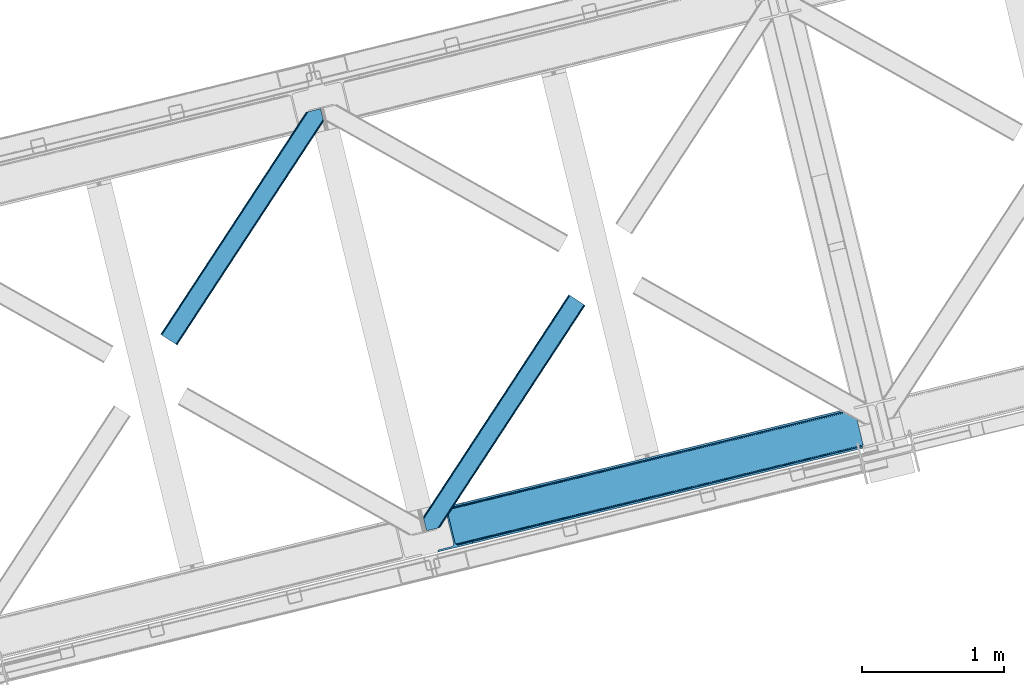
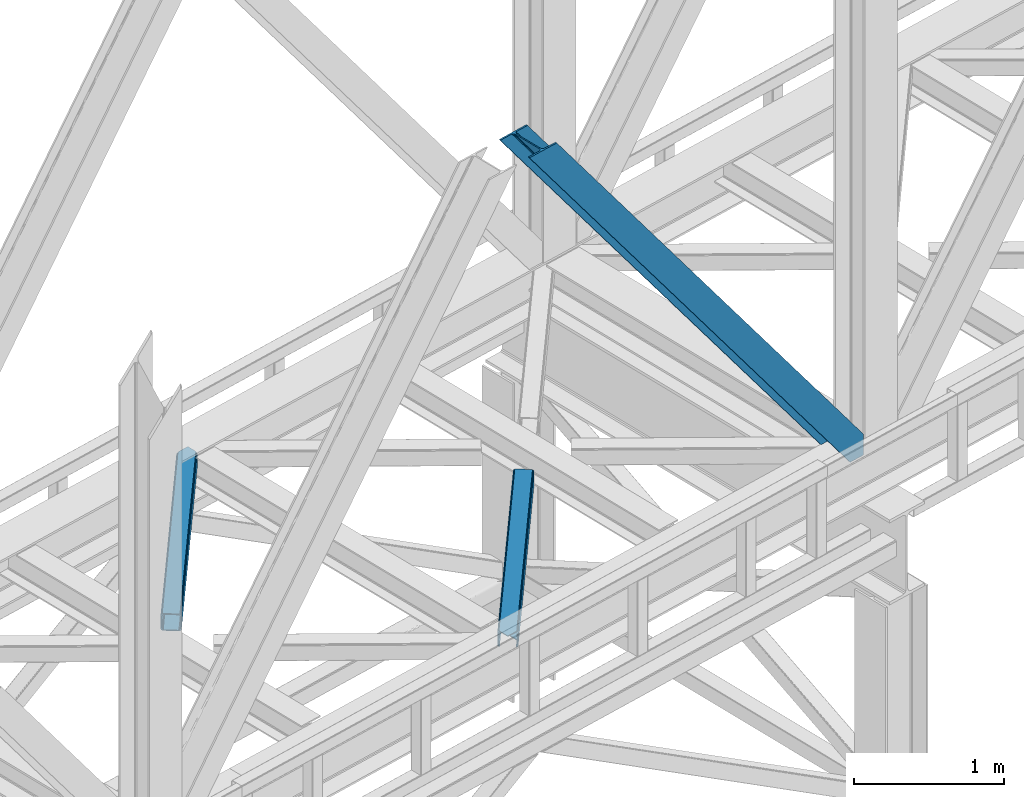
# One storey, part 48 of 92: 3 members.
"""IFC4 building model written with IfcOpenShell, lengths in millimetres."""

from ifc_helpers import new_model, entity, si_unit, converted_unit, derived_unit, direction, frame, origin, place, context, subcontext, project, spatial, triangles, type_object, element, save


model = new_model("IFC4")

# Units and contexts
model_context = context("Model", 3, precision=0.01, world=origin(), true_north=direction((6.12303176911189e-17, 1.0)))
plan_context = context("Plan", 3, precision=0.01, world=origin(), true_north=direction((6.12303176911189e-17, 1.0)))
body_context = subcontext(model_context, "Body", "Model", "MODEL_VIEW")
ifc_project = project(units=[si_unit("LENGTHUNIT", "METRE", prefix="MILLI"), si_unit("AREAUNIT", "SQUARE_METRE"), si_unit("VOLUMEUNIT", "CUBIC_METRE"), converted_unit("PLANEANGLEUNIT", "DEGREE", entity("IfcRatioMeasure", 0.0174532925199433), si_unit("PLANEANGLEUNIT", "RADIAN"), dimensions=[0, 0, 0, 0, 0, 0, 0]), si_unit("MASSUNIT", "GRAM", prefix="KILO"), derived_unit("MASSDENSITYUNIT", [(si_unit("MASSUNIT", "GRAM", prefix="KILO"), 1), (si_unit("LENGTHUNIT", "METRE"), -3)]), derived_unit("MOMENTOFINERTIAUNIT", [(si_unit("LENGTHUNIT", "METRE"), 4)]), si_unit("TIMEUNIT", "SECOND"), si_unit("FREQUENCYUNIT", "HERTZ"), si_unit("THERMODYNAMICTEMPERATUREUNIT", "DEGREE_CELSIUS"), derived_unit("THERMALTRANSMITTANCEUNIT", [(si_unit("MASSUNIT", "GRAM", prefix="KILO"), 1), (si_unit("THERMODYNAMICTEMPERATUREUNIT", "KELVIN"), -1), (si_unit("TIMEUNIT", "SECOND"), -3)]), derived_unit("VOLUMETRICFLOWRATEUNIT", [(si_unit("LENGTHUNIT", "METRE"), 3), (si_unit("TIMEUNIT", "SECOND"), -1)]), derived_unit("MASSFLOWRATEUNIT", [(si_unit("MASSUNIT", "GRAM", prefix="KILO"), 1), (si_unit("TIMEUNIT", "SECOND"), -1)]), derived_unit("ROTATIONALFREQUENCYUNIT", [(si_unit("TIMEUNIT", "SECOND"), -1)]), si_unit("ELECTRICCURRENTUNIT", "AMPERE"), si_unit("ELECTRICVOLTAGEUNIT", "VOLT"), si_unit("POWERUNIT", "WATT"), si_unit("FORCEUNIT", "NEWTON", prefix="KILO"), si_unit("ILLUMINANCEUNIT", "LUX"), si_unit("LUMINOUSFLUXUNIT", "LUMEN"), si_unit("LUMINOUSINTENSITYUNIT", "CANDELA"), derived_unit("USERDEFINED", [(si_unit("MASSUNIT", "GRAM", prefix="KILO"), -1), (si_unit("LENGTHUNIT", "METRE"), -2), (si_unit("TIMEUNIT", "SECOND"), 3), (si_unit("LUMINOUSFLUXUNIT", "LUMEN"), 1)]), derived_unit("LINEARVELOCITYUNIT", [(si_unit("LENGTHUNIT", "METRE"), 1), (si_unit("TIMEUNIT", "SECOND"), -1)]), si_unit("PRESSUREUNIT", "PASCAL"), derived_unit("USERDEFINED", [(si_unit("LENGTHUNIT", "METRE"), -2), (si_unit("MASSUNIT", "GRAM", prefix="KILO"), 1), (si_unit("TIMEUNIT", "SECOND"), -2)]), derived_unit("LINEARFORCEUNIT", [(si_unit("MASSUNIT", "GRAM", prefix="KILO"), 1), (si_unit("LENGTHUNIT", "METRE"), 1), (si_unit("TIMEUNIT", "SECOND"), -2), (si_unit("LENGTHUNIT", "METRE"), -1)]), derived_unit("PLANARFORCEUNIT", [(si_unit("MASSUNIT", "GRAM", prefix="KILO"), 1), (si_unit("LENGTHUNIT", "METRE"), 1), (si_unit("TIMEUNIT", "SECOND"), -2), (si_unit("LENGTHUNIT", "METRE"), -2)])], contexts=[model_context, plan_context])

# Site, building, storey
site_placement = place(None, origin())
site = spatial("IfcSite", under=ifc_project, at=site_placement, CompositionType="ELEMENT")
building_placement = place(site_placement, origin())
building = spatial("IfcBuilding", under=site, at=building_placement, CompositionType="ELEMENT")
storey_placement = place(building_placement, frame((0.0, 0.0, 15900.0)))
storey = spatial("IfcBuildingStorey", under=building, at=storey_placement, Name="05", CompositionType="ELEMENT", Elevation=15900.0)

# Members
member_type_1 = type_object("IfcMemberType", PredefinedType="BRACE")
member_1_placement = place(storey_placement, frame((-38975.88, 7966.0, 3695.0)))
element("IfcMember", 1, at=member_1_placement, inside=storey, type_object=member_type_1, ObjectType="Steel Vertical Brace", PredefinedType="BRACE", context=body_context, shape_type="Tessellation", body=[
    triangles([(3067.37323608399, 755.491676330566, 0.827856445310317), (3068.02901000977, 754.507434082031, 1.13248901367115), (3066.60119018555, 754.04641571045, 0.0), (3064.68037719727, 761.9255859375, 0.0), (3064.2176147461, 752.731379699707, 7.29955444335792), (3064.2176147461, 752.731379699707, 0.0), (3059.99926757813, 741.22801208496, 0.0), (3059.68998413086, 743.592402648926, 30.563250732419), (3059.80625610352, 742.210510253905, 42.2602111816377), (3059.81788330078, 745.528330993652, 0.0), (3059.81788330078, 745.528330993652, 24.1799194335908), (3059.80625610352, 742.210510253905, 171.115136718749), (3059.99926757813, 741.22801208496, 171.175598144531), (3061.30151367188, 749.56936340332, 14.6921264648408), (3061.30151367188, 749.56936340332, 0.0), (3060.72247924805, 747.995040893554, 18.3872497558586), (215.726367187504, 48.9359664916992, 3911.00081176758), (310.453143310551, 72.0269989013668, 3911.00081176758), (192.837066650391, 54.7931671142578, 3911.00081176758), (198.973901367193, 50.2783264160153, 3911.00081176758), (207.010620117188, 48.221475219726, 3911.00081176758), (189.534942626953, 61.0788299560545, 3911.00081176758), (3062.84095458985, 729.569421386718, 171.175598144531), (313.532025146487, 59.3963745117189, 3911.00081176758), (3062.84095458985, 729.569421386718, 0.0), (2945.0109375, 700.847337341308, 0.0), (69.8655029296933, 0.0, 3911.00081176758), (2941.93205566407, 713.477380371093, 0.0), (66.78662109375, 12.6300430297852, 3911.00081176758), (161.51107177735, 35.72049407959, 3911.00081176758), (3036.65650634766, 736.567831420899, 0.0), (3054.3251953125, 759.401321411132, 0.0), (3054.28798828126, 752.302336120606, 0.0), (179.17976074219, 58.5539840698239, 3911.00081176758), (179.140228271484, 51.4549987792971, 3911.00081176758), (3050.91610107422, 745.46961364746, 0.0), (175.770666503908, 44.6222763061523, 3911.00081176758), (3044.72578125, 739.944950866699, 0.0), (169.580346679693, 39.0976135253904, 3911.00081176758), (2999.1448425293, 985.772969055176, 0.0), (123.999407958989, 284.925631713867, 3911.00081176758), (2972.9510925293, 997.915251159669, 0.0), (2981.66916503906, 998.629742431641, 0.0), (106.5214050293, 297.782405090332, 3911.00081176758), (97.8056579589902, 297.06791381836, 3911.00081176758), (2989.70820922852, 996.572891235351, 0.0), (114.560449218756, 295.725553894044, 3911.00081176758), (2995.84271850586, 992.058631896972, 0.0), (120.697283935551, 291.211294555665, 3911.00081176758), (3.07888183594332, 273.977462768554, 3911.00081176758), (2878.22664184571, 974.824800109863, 0.0), (2875.14776000977, 987.454843139648, 0.0), (0.0, 286.607505798339, 3911.00081176758), (3009.50002441407, 988.297233581542, 0.0), (134.354589843751, 287.450477600097, 3911.00081176758), (143.954003906256, 306.906848144531, 3911.00081176758), (243.668847656256, 346.004461669922, 3911.00081176758), (152.020953369145, 310.283386230468, 3911.00081176758), (137.763684082034, 301.381604003906, 3911.00081176758), (134.394122314457, 294.549462890624, 3911.00081176758), (246.747729492192, 333.374418640137, 3911.00081176758), (2992.97777709962, 1016.17750854492, 171.175598144531), (2992.97777709962, 1016.17750854492, 0.0), (2995.81946411133, 1004.51891784668, 171.175598144531), (2996.0985168457, 1003.55792999267, 171.115136718749), (2996.0985168457, 1003.55792999267, 42.2602111816377), (2995.81946411133, 1004.51891784668, 0.0), (3004.85844726563, 996.247329711913, 0.0), (2997.63795776368, 1000.6174118042, 0.0), (3000.81218261719, 997.712356567382, 0.0), (3007.57921142579, 996.17582244873, 0.0), (2996.63104248047, 1002.27719421387, 30.563250732419), (2997.8007385254, 1000.74124145508, 25.1542785644524), (2999.21228027344, 998.89019165039, 18.6337463378877), (3000.81218261719, 997.712356567382, 14.6921264648408), (3004.85844726563, 996.247329711913, 7.29955444335792), (3009.05819091797, 996.424063110352, 1.13248901367115), (3008.93029174805, 995.247972106933, 0.827856445310317)], [[1, 2, 3], [3, 4, 1], [5, 6, 3], [7, 8, 9], [7, 10, 11], [11, 8, 7], [9, 12, 13], [13, 7, 9], [14, 10, 15], [10, 14, 16], [11, 10, 16], [6, 5, 15], [14, 15, 5], [3, 2, 5], [17, 18, 12], [12, 9, 17], [1, 19, 5], [19, 20, 16], [16, 14, 19], [14, 5, 19], [20, 21, 8], [8, 11, 20], [9, 8, 21], [21, 17, 9], [11, 16, 20], [5, 2, 1], [1, 4, 19], [22, 19, 4], [13, 12, 18], [23, 13, 24], [18, 24, 13], [23, 25, 7], [7, 13, 23], [24, 26, 23], [24, 27, 26], [26, 25, 23], [28, 26, 29], [27, 29, 26], [29, 30, 28], [31, 28, 30], [32, 33, 34], [35, 34, 33], [33, 36, 35], [37, 35, 36], [36, 38, 37], [39, 37, 38], [38, 31, 39], [30, 39, 31], [40, 32, 34], [34, 41, 40], [42, 43, 44], [44, 45, 42], [43, 46, 47], [47, 44, 43], [46, 48, 49], [49, 47, 46], [48, 40, 41], [41, 49, 48], [45, 50, 51], [51, 42, 45], [52, 51, 50], [50, 53, 52], [4, 54, 55], [55, 22, 4], [41, 34, 55], [37, 39, 21], [30, 27, 24], [29, 27, 30], [39, 30, 17], [34, 35, 19], [35, 37, 20], [47, 56, 44], [53, 45, 57], [45, 44, 58], [53, 50, 45], [47, 49, 59], [49, 41, 60], [55, 34, 22], [17, 21, 39], [19, 35, 20], [21, 20, 37], [19, 22, 34], [24, 17, 30], [24, 18, 17], [58, 44, 56], [59, 49, 60], [55, 60, 41], [59, 56, 47], [58, 57, 45], [57, 58, 61], [57, 52, 53], [52, 57, 62], [63, 52, 62], [64, 62, 57], [65, 64, 61], [57, 61, 64], [61, 58, 65], [66, 65, 58], [64, 67, 62], [63, 62, 67], [32, 40, 54], [46, 43, 67], [42, 52, 63], [51, 52, 42], [43, 42, 63], [40, 48, 68], [48, 46, 69], [36, 7, 38], [26, 31, 25], [31, 38, 25], [26, 28, 31], [36, 33, 10], [33, 32, 6], [10, 7, 36], [54, 40, 68], [67, 69, 46], [63, 67, 43], [48, 69, 70], [70, 68, 48], [71, 54, 68], [32, 54, 4], [10, 33, 15], [33, 6, 15], [7, 25, 38], [32, 4, 6], [3, 6, 4], [67, 72, 73], [65, 66, 64], [67, 64, 66], [66, 72, 67], [69, 74, 75], [69, 73, 74], [76, 77, 71], [71, 68, 76], [76, 68, 70], [70, 75, 76], [75, 70, 69], [73, 69, 67], [60, 78, 76], [76, 59, 60], [76, 75, 59], [75, 74, 59], [78, 77, 76], [54, 78, 60], [60, 55, 54], [73, 59, 74], [59, 73, 72], [56, 59, 72], [72, 66, 56], [58, 56, 66], [77, 78, 71], [54, 71, 78]]),
])
member_type_2 = type_object("IfcMemberType", PredefinedType="BRACE")
member_2_placement = place(storey_placement, frame((-40863.02, 9423.03, 3511.0)))
element("IfcMember", 2, at=member_2_placement, inside=storey, type_object=member_type_2, ObjectType="Steel Horizontal Brace", PredefinedType="BRACE", context=body_context, shape_type="Tessellation", body=[
    triangles([(994.776489257813, 1564.02720794678, 0.0), (1028.82557373047, 1424.34736175537, 0.0), (14.6409667968765, 67.1040435791001, 0.0), (102.486767578128, 9.58604278564417, 0.0), (1.1162109375, 75.9604797363281, 10.8028289794929), (0.0, 76.6900863647461, 17.5000946044929), (1025.02580566407, 1642.17825164795, 17.5000946044929), (4.28811035156104, 73.8821182250977, 5.12526855468968), (990.47907714844, 1585.87703704834, 9.50058288574292), (990.041894531249, 1584.44689178467, 8.74132690429906), (989.90701904297, 1583.99226837158, 8.50064392089917), (990.762780761717, 1580.48783111572, 5.12526855468968), (1027.30938720703, 1642.73519439697, 10.8702667236357), (1027.77912597657, 1642.8503036499, 9.50058288574292), (992.604528808595, 1572.9359664917, 1.33247680664135), (9.03665771484521, 70.7724243164048, 1.33247680664135), (1025.02580566407, 1642.17825164795, 122.500662231447), (0.0, 76.6900863647461, 122.500662231447), (1026.92336425781, 1642.64101409912, 129.197927856447), (1.1162109375, 75.9604797363281, 129.197927856447), (1032.31838378906, 1643.95605010986, 134.874325561526), (4.28811035156104, 73.8821182250977, 134.874325561526), (1040.39230957031, 1645.92453460693, 138.667117309571), (9.03665771484521, 70.7724243164048, 138.667117309571), (1049.91730957032, 1648.24648590088, 139.999594116212), (14.6409667968765, 67.1040435791001, 139.999594116212), (994.874157714847, 1567.85139312744, 9.50058288574292), (994.762536621092, 1567.00725860596, 9.29478149414354), (994.650915527345, 1566.15033416748, 9.08781738281323), (994.539294433598, 1565.30619964599, 8.8831787109375), (994.748583984379, 1564.14464263916, 8.50064392089917), (1047.05701904297, 1647.54769134521, 9.50058288574292), (14.892114257811, 66.9377746582031, 8.3320495605476), (20.4964233398423, 63.2693939208984, 6.99957275390625), (997.046118164064, 1554.71498565674, 6.99957275390625), (10.1435668945342, 70.0474685668942, 12.1260040283232), (1042.27591552735, 1646.3826461792, 12.1260040283232), (1036.8808959961, 1645.06761016846, 17.8035644531265), (1034.98333740234, 1644.60601043701, 24.4996673583992), (6.97166748047312, 72.1258300781246, 17.8035644531265), (5.85545654297312, 72.8560180664063, 24.4996673583992), (1026.55129394531, 1433.65958404541, 6.99957275390625), (96.6313110351548, 13.4206924438477, 6.99957275390625), (1028.71860351563, 1424.77640533447, 8.41343994140698), (1032.83463134766, 1407.88673858643, 5.12526855468968), (1033.6903930664, 1404.38230133057, 8.50064392089917), (1030.99288330078, 1415.43860321045, 1.33247680664135), (1034.98333740234, 1644.60601043701, 115.501089477541), (5.85545654297312, 72.8560180664063, 115.501089477541), (1050.3498413086, 1648.35113067627, 131.667544555665), (1059.87484130859, 1650.67308197021, 133.000021362306), (20.4964233398423, 63.2693939208984, 133.000021362306), (14.892114257811, 66.9377746582031, 131.667544555665), (1042.27591552735, 1646.3826461792, 127.87475280762), (10.1435668945342, 70.0474685668942, 127.87475280762), (1036.8808959961, 1645.06761016846, 122.196029663086), (6.97166748047312, 72.1258300781246, 122.196029663086), (1128.10788574219, 1667.30578765869, 139.999594116212), (1128.10788574219, 1667.30578765869, 133.000021362306), (1144.33015136719, 1600.75868682861, 139.999594116212), (102.486767578128, 9.58604278564417, 139.999594116212), (1142.06052246094, 1610.06974639893, 133.000021362306), (96.6313110351548, 13.4206924438477, 133.000021362306), (1146.50211181641, 1591.84876556396, 138.667117309571), (108.091076660159, 5.91766204833948, 138.667117309571), (1148.34385986329, 1584.29690093994, 134.874325561526), (112.839624023436, 2.80738677978479, 134.874325561526), (1149.57169189453, 1579.25069732666, 129.197927856447), (116.011523437504, 0.729606628417969, 129.197927856447), (1150.00422363282, 1577.47871246338, 122.500662231447), (117.127734375004, 0.0, 122.500662231447), (1150.00422363282, 1577.47871246338, 17.5000946044929), (117.127734375004, 0.0, 17.5000946044929), (106.98416748047, 6.64203643798828, 127.87475280762), (110.156066894531, 4.56367492675781, 122.196029663086), (111.272277832031, 3.83464965820167, 115.501089477541), (102.230969238284, 9.75173034667932, 131.667544555665), (116.011523437504, 0.729606628417969, 10.8028289794929), (106.98416748047, 6.64203643798828, 12.1260040283232), (112.839624023436, 2.80738677978479, 5.12526855468968), (111.272277832031, 3.83464965820167, 24.4996673583992), (110.156066894531, 4.56367492675781, 17.8035644531265), (108.091076660159, 5.91766204833948, 1.33247680664135), (102.230969238284, 9.75173034667932, 8.3320495605476), (1147.30206298828, 1588.56175689697, 122.196029663086), (1147.73459472656, 1586.78977203369, 115.501089477541), (1146.07423095703, 1593.60912322998, 127.87475280762), (1144.23248291016, 1601.160987854, 131.667544555665), (1147.73459472656, 1586.78977203369, 24.4996673583992), (1147.21369628907, 1588.92452545166, 17.869839477542), (1149.994921875, 1577.51591949463, 16.5001556396492), (1147.10672607422, 1589.36519622803, 16.5001556396492), (1145.27427978516, 1573.10804901123, 10.8714294433594), (1034.62056884765, 1404.78809051514, 9.50058288574292), (1144.12551269531, 1572.03369598389, 9.50058288574292), (1142.79071044922, 1588.5978012085, 12.1260040283232), (1030.22548828125, 1422.81373443603, 9.50058288574292), (1029.19764404297, 1423.67182159424, 8.80643920898729), (1139.7304321289, 1590.06050262451, 9.50058288574292)], [[1, 2, 3], [4, 3, 2], [5, 6, 7], [8, 9, 10], [11, 12, 8], [5, 13, 9], [9, 8, 5], [13, 14, 9], [15, 1, 16], [3, 16, 1], [12, 15, 8], [16, 8, 15], [7, 13, 5], [17, 7, 6], [6, 18, 17], [19, 17, 20], [18, 20, 17], [21, 19, 22], [20, 22, 19], [23, 21, 24], [22, 24, 21], [25, 23, 26], [24, 26, 23], [27, 28, 9], [28, 29, 10], [29, 30, 10], [30, 31, 11], [14, 32, 27], [27, 9, 14], [33, 34, 35], [36, 33, 31], [31, 30, 36], [28, 36, 29], [28, 27, 36], [36, 30, 29], [32, 37, 27], [36, 27, 37], [35, 31, 33], [38, 39, 40], [41, 40, 39], [37, 38, 36], [40, 36, 38], [42, 35, 34], [34, 43, 42], [1, 35, 42], [31, 12, 11], [1, 31, 35], [31, 15, 12], [31, 1, 15], [2, 1, 42], [44, 2, 42], [45, 44, 46], [44, 47, 2], [44, 45, 47], [39, 48, 41], [49, 41, 48], [50, 51, 52], [52, 53, 50], [54, 50, 53], [53, 55, 54], [56, 54, 55], [55, 57, 56], [48, 56, 57], [57, 49, 48], [56, 17, 19], [50, 23, 25], [58, 51, 25], [51, 58, 59], [51, 50, 25], [54, 23, 50], [54, 56, 21], [21, 23, 54], [19, 21, 56], [39, 7, 17], [37, 14, 38], [56, 48, 17], [37, 32, 14], [39, 38, 7], [48, 39, 17], [13, 7, 38], [38, 14, 13], [60, 25, 61], [25, 60, 58], [26, 61, 25], [51, 62, 63], [51, 59, 62], [63, 52, 51], [64, 60, 61], [61, 65, 64], [66, 64, 65], [65, 67, 66], [68, 66, 67], [67, 69, 68], [70, 68, 69], [69, 71, 70], [72, 70, 71], [71, 73, 72], [69, 74, 75], [76, 73, 71], [69, 75, 71], [69, 67, 74], [75, 76, 71], [74, 67, 65], [63, 61, 26], [61, 77, 65], [77, 61, 63], [77, 74, 65], [78, 79, 80], [81, 73, 76], [73, 82, 78], [82, 73, 81], [78, 82, 79], [4, 43, 3], [83, 80, 79], [79, 84, 83], [84, 43, 4], [4, 83, 84], [55, 24, 22], [26, 52, 63], [26, 53, 52], [53, 26, 24], [55, 53, 24], [49, 18, 6], [20, 57, 55], [22, 20, 55], [57, 20, 18], [49, 57, 18], [16, 36, 8], [3, 43, 34], [34, 33, 3], [33, 36, 16], [16, 3, 33], [5, 8, 36], [6, 41, 49], [40, 6, 5], [6, 40, 41], [40, 5, 36], [85, 86, 75], [76, 75, 86], [87, 85, 74], [75, 74, 85], [88, 87, 77], [74, 77, 87], [62, 88, 63], [77, 63, 88], [86, 89, 76], [81, 76, 89], [90, 91, 92], [70, 72, 89], [72, 90, 89], [89, 86, 70], [72, 91, 90], [85, 70, 86], [68, 70, 85], [66, 85, 87], [85, 66, 68], [87, 64, 66], [88, 64, 87], [88, 62, 60], [88, 60, 64], [62, 58, 60], [62, 59, 58], [73, 78, 93], [93, 72, 73], [94, 93, 78], [94, 95, 93], [80, 45, 46], [46, 78, 80], [46, 94, 78], [47, 45, 83], [80, 83, 45], [2, 47, 4], [83, 4, 47], [93, 91, 72], [82, 81, 89], [82, 92, 96], [82, 90, 92], [84, 97, 98], [79, 96, 97], [97, 84, 79], [96, 99, 97], [43, 84, 44], [44, 42, 43], [96, 79, 82], [89, 90, 82], [96, 91, 93], [96, 92, 91], [96, 95, 99], [93, 95, 96], [99, 95, 97], [94, 97, 95]]),
])
member_type_3 = type_object("IfcMemberType", PredefinedType="BRACE")
member_3_placement = place(storey_placement, frame((-39011.7, 8114.1, 3511.0)))
element("IfcMember", 3, at=member_3_placement, inside=storey, type_object=member_type_3, ObjectType="Steel Horizontal Brace", PredefinedType="BRACE", context=body_context, shape_type="Tessellation", body=[
    triangles([(109.770043945311, 259.950411987305, 7.52047119140843), (115.030187988283, 238.366264343263, 7.77510681152489), (114.216284179689, 239.946981811524, 8.3320495605476), (108.809637451173, 259.66263885498, 8.52041015625218), (113.637249755855, 239.860359191895, 8.52041015625218), (112.209429931638, 237.677934265136, 8.52041015625218), (91.0363037109346, 232.516621398926, 8.52041015625218), (109.537499999999, 237.026811218261, 9.50058288574292), (90.2619323730469, 232.328260803223, 9.50058288574292), (5.02062377929542, 77.405158996582, 9.50058288574292), (0.62786865234375, 95.4313842773436, 9.50058288574292), (1046.62448730469, 1651.75382995606, 6.99957275390625), (1041.02017822266, 1655.42221069336, 8.3320495605476), (116.702178955078, 231.514938354493, 6.99957275390625), (1036.27395629883, 1658.53248596192, 12.1260040283232), (3.93231811523583, 81.8758163452158, 12.1260040283232), (1033.09740600586, 1660.61026611328, 17.8035644531265), (2.70216064452688, 86.922019958497, 17.8035644531265), (1031.98352050781, 1661.34045410156, 24.4996673583992), (2.26962890625146, 88.6940048217775, 24.4996673583992), (1122.75704956055, 1601.905128479, 6.99957275390625), (146.20968017578, 110.459536743164, 6.99957275390625), (1031.98352050781, 1661.34045410156, 115.501089477541), (2.26962890625146, 88.6940048217775, 115.501089477541), (1033.09740600586, 1660.61026611328, 122.196029663086), (2.70216064452688, 86.922019958497, 122.196029663086), (1036.27395629883, 1658.53248596192, 127.87475280762), (3.93231811523583, 81.8758163452158, 127.87475280762), (1041.02017822266, 1655.42221069336, 131.667544555665), (5.77174072265188, 74.3233703613287, 131.667544555665), (1046.62448730469, 1651.75382995606, 133.000021362306), (7.94370117187646, 65.4146118164063, 133.000021362306), (1027.24194946289, 1664.44491577149, 10.8028289794929), (0.518572998043965, 95.8720550537118, 10.8691040039084), (0.0, 98.0062271118159, 17.5000946044929), (1035.16472167968, 1659.25686035156, 1.33247680664135), (112.260589599609, 249.735919189453, 1.33247680664135), (110.544415283199, 256.772117614747, 5.59500732422021), (109.077062988283, 259.839953613281, 8.31925964355469), (1030.41384887695, 1662.36713562012, 5.12526855468968), (1040.76670532226, 1655.58847961426, 0.0), (114.430224609372, 240.827160644531, 0.0), (1026.12806396484, 1665.17510375977, 17.5000946044929), (1128.61250610351, 1598.0704788208, 0.0), (148.479309082031, 101.147895812989, 0.0), (150.651269531249, 92.2391372680659, 1.33247680664135), (148.509539794919, 101.029879760742, 8.50064392089917), (152.493017578126, 84.6866912841806, 5.12526855468968), (153.346453857419, 81.1828353881838, 8.50064392089917), (1026.12806396484, 1665.17510375977, 122.500662231447), (0.0, 98.0062271118159, 122.500662231447), (1040.76670532226, 1655.58847961426, 139.999594116212), (1035.16472167968, 1659.25686035156, 138.667117309571), (3.50211181640771, 83.6350112915034, 138.667117309571), (5.674072265625, 74.7262527465818, 139.999594116212), (1030.41384887695, 1662.36713562012, 134.874325561526), (1.66036376952979, 91.1874572753904, 134.874325561526), (1027.24194946289, 1664.44491577149, 129.197927856447), (0.430206298828125, 96.2342422485353, 129.197927856447), (23.8892395019502, 0.0, 139.999594116212), (23.8892395019502, 0.0, 133.000021362306), (1128.61250610351, 1598.0704788208, 139.999594116212), (93.3361633300738, 16.9286178588873, 139.999594116212), (1122.75704956055, 1601.905128479, 133.000021362306), (83.3809570312515, 14.5020217895508, 133.000021362306), (1143.25347290039, 1588.48443603516, 122.500662231447), (1142.13958740234, 1589.21404266358, 129.197927856447), (118.225341796875, 22.9956893920898, 122.500662231447), (116.332434082033, 22.5340896606449, 129.197927856447), (1138.96536254883, 1591.29182281494, 134.874325561526), (110.935089111328, 21.2184722900392, 134.874325561526), (1134.21681518554, 1594.40267944336, 138.667117309571), (102.861163330075, 19.2499877929686, 138.667117309571), (1143.25347290039, 1588.48443603516, 17.5000946044929), (118.225341796875, 22.9956893920898, 17.5000946044929), (1142.13958740234, 1589.21404266358, 10.8028289794929), (1133.10990600586, 1595.12647247315, 12.1260040283232), (1136.28180541992, 1593.04811096192, 17.8035644531265), (1137.39801635742, 1592.31908569336, 24.4996673583992), (1138.96536254883, 1591.29182281494, 5.12526855468968), (1134.21681518554, 1594.40267944336, 1.33247680664135), (1128.35903320312, 1598.2367477417, 8.3320495605476), (1133.10990600586, 1595.12647247315, 127.87475280762), (1137.39801635742, 1592.31908569336, 115.501089477541), (1136.28180541992, 1593.04811096192, 122.196029663086), (1128.35903320312, 1598.2367477417, 131.667544555665), (92.9059570312456, 16.8239730834966, 131.667544555665), (100.979882812499, 18.7918762207037, 127.87475280762), (106.374902343749, 20.1069122314457, 122.196029663086), (108.270135498045, 20.5685119628906, 115.501089477541), (108.270135498045, 20.5685119628906, 24.4996673583992), (100.979882812499, 18.7918762207037, 12.1260040283232), (115.474346923824, 22.3248001098636, 9.50058288574292), (106.374902343749, 20.1069122314457, 17.8035644531265), (96.2011047363267, 17.6268310546875, 9.50058288574292), (115.944085693358, 22.4393280029299, 10.8702667236357), (153.060424804688, 80.2398696899409, 9.00061340332104), (152.776721191403, 79.2974853515634, 9.50058288574292), (148.711853027344, 99.8683227539068, 8.8831787109375), (148.602557373044, 99.023606872558, 9.08781738281323), (148.493261718751, 98.1678451538091, 9.29478149414354), (148.381640624997, 97.3231292724604, 9.50058288574292)], [[1, 2, 3], [4, 5, 6], [6, 7, 4], [7, 6, 8], [8, 9, 7], [9, 8, 10], [10, 11, 9], [12, 13, 3], [3, 2, 12], [2, 14, 12], [15, 16, 8], [8, 13, 15], [8, 5, 13], [16, 10, 8], [8, 6, 5], [15, 17, 18], [18, 16, 15], [17, 19, 20], [20, 18, 17], [21, 12, 14], [14, 22, 21], [19, 23, 20], [24, 20, 23], [23, 25, 24], [26, 24, 25], [25, 27, 26], [28, 26, 27], [27, 29, 28], [30, 28, 29], [29, 31, 30], [32, 30, 31], [33, 34, 35], [36, 37, 38], [33, 4, 9], [33, 1, 39], [9, 34, 33], [9, 11, 34], [4, 7, 9], [40, 38, 1], [1, 33, 40], [38, 40, 36], [36, 41, 37], [42, 37, 41], [35, 43, 33], [41, 44, 42], [45, 42, 44], [14, 42, 22], [37, 2, 38], [2, 37, 42], [38, 2, 1], [42, 14, 2], [22, 42, 45], [46, 47, 45], [47, 46, 48], [45, 47, 22], [48, 49, 47], [50, 43, 35], [35, 51, 50], [52, 53, 54], [54, 55, 52], [53, 56, 57], [57, 54, 53], [56, 58, 59], [59, 57, 56], [58, 50, 51], [51, 59, 58], [28, 57, 26], [30, 32, 55], [32, 60, 55], [32, 61, 60], [54, 30, 55], [28, 54, 57], [16, 11, 10], [28, 30, 54], [51, 35, 20], [24, 26, 51], [24, 51, 20], [57, 59, 26], [26, 59, 51], [35, 18, 20], [18, 11, 16], [11, 18, 34], [35, 34, 18], [62, 55, 63], [62, 52, 55], [55, 60, 63], [64, 32, 31], [32, 64, 65], [61, 32, 65], [66, 67, 68], [69, 68, 67], [67, 70, 69], [71, 69, 70], [70, 72, 71], [73, 71, 72], [72, 62, 73], [63, 73, 62], [74, 66, 68], [68, 75, 74], [76, 77, 78], [79, 66, 74], [76, 78, 74], [76, 80, 77], [78, 79, 74], [77, 80, 81], [21, 44, 41], [44, 82, 81], [82, 44, 21], [82, 77, 81], [67, 83, 70], [84, 66, 79], [66, 85, 67], [85, 66, 84], [67, 85, 83], [62, 64, 52], [72, 70, 83], [83, 86, 72], [86, 64, 62], [62, 72, 86], [15, 36, 40], [41, 12, 21], [41, 13, 12], [13, 41, 36], [15, 13, 36], [19, 43, 50], [33, 17, 15], [40, 33, 15], [17, 33, 43], [19, 17, 43], [53, 27, 56], [52, 64, 31], [31, 29, 52], [29, 27, 53], [53, 52, 29], [58, 56, 27], [50, 23, 19], [25, 50, 58], [50, 25, 23], [25, 58, 27], [64, 86, 87], [87, 65, 64], [86, 83, 88], [88, 87, 86], [83, 85, 89], [89, 88, 83], [85, 84, 90], [90, 89, 85], [84, 79, 90], [91, 90, 79], [89, 68, 69], [87, 73, 63], [60, 65, 63], [65, 60, 61], [65, 87, 63], [88, 73, 87], [88, 89, 71], [71, 73, 88], [69, 71, 89], [91, 75, 68], [92, 93, 94], [89, 90, 68], [92, 95, 93], [91, 94, 75], [90, 91, 68], [96, 75, 94], [94, 93, 96], [76, 74, 75], [49, 80, 97], [98, 97, 80], [49, 48, 80], [76, 96, 98], [98, 80, 76], [96, 93, 98], [44, 81, 45], [46, 45, 81], [81, 80, 46], [48, 46, 80], [75, 96, 76], [82, 21, 22], [77, 82, 47], [47, 99, 77], [77, 100, 101], [100, 77, 99], [101, 102, 77], [77, 102, 92], [95, 92, 102], [22, 47, 82], [79, 78, 91], [94, 91, 78], [78, 77, 94], [92, 94, 77], [102, 101, 98], [101, 100, 97], [100, 99, 49], [99, 47, 49], [102, 98, 93], [93, 95, 102]]),
])

save(model, "model.ifc")
